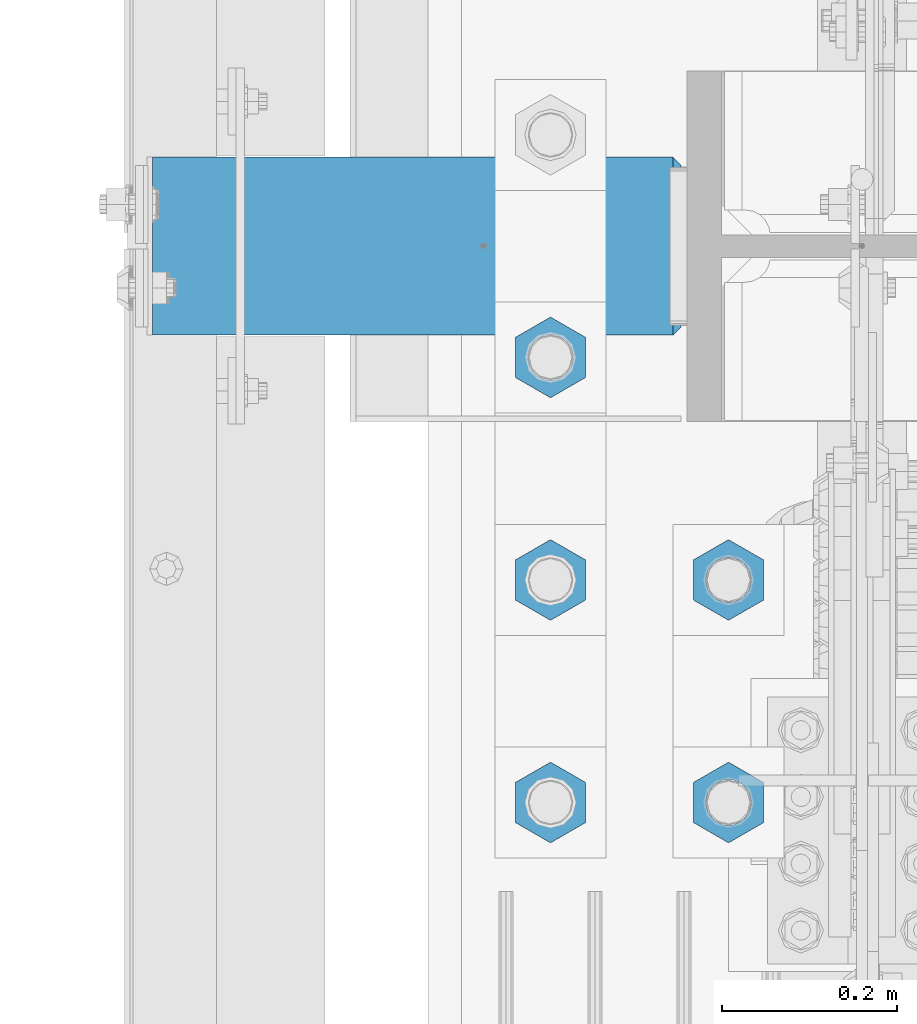
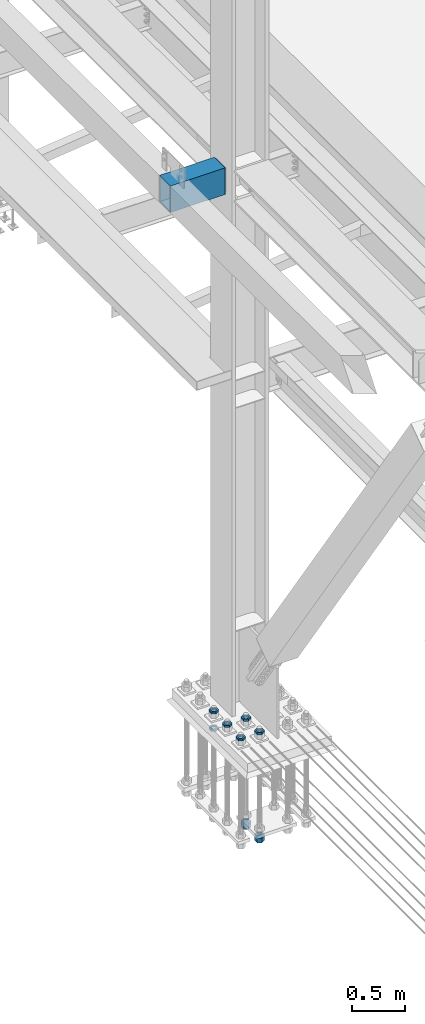
# One storey, part 2382 of 3843: 11 beams, 2 elements without a shape of their own.
"""IFC2X3 building model written with IfcOpenShell, lengths in millimetres."""

from ifc_helpers import new_model, si_unit, frame, origin_with_axes, place, context, subcontext, project, spatial, faceted_brep, material, type_object, element, aggregate, save


model = new_model("IFC2X3")

# Units and contexts
model_context = context("Model", 3, precision=1e-05, world=origin_with_axes())
body_context = subcontext(model_context, "Body", "Model", "MODEL_VIEW")
ifc_project = project(units=[si_unit("LENGTHUNIT", "METRE", prefix="MILLI"), si_unit("AREAUNIT", "SQUARE_METRE"), si_unit("VOLUMEUNIT", "CUBIC_METRE"), si_unit("MASSUNIT", "GRAM", prefix="KILO"), si_unit("TIMEUNIT", "SECOND"), si_unit("PLANEANGLEUNIT", "RADIAN"), si_unit("SOLIDANGLEUNIT", "STERADIAN"), si_unit("THERMODYNAMICTEMPERATUREUNIT", "DEGREE_CELSIUS"), si_unit("LUMINOUSINTENSITYUNIT", "LUMEN")], contexts=[model_context])

# Site, building, storey
site_placement = place(None, origin_with_axes())
site = spatial("IfcSite", under=ifc_project, at=site_placement, CompositionType="ELEMENT")
building_placement = place(site_placement, origin_with_axes())
building = spatial("IfcBuilding", under=site, at=building_placement, Name="Undefined", CompositionType="ELEMENT")
storey_placement = place(building_placement, origin_with_axes())
storey = spatial("IfcBuildingStorey", under=building, at=storey_placement, Name="Undefined", CompositionType="ELEMENT", Elevation=0.0)

# Assembly, beams
assembly_1_placement = place(storey_placement, origin_with_axes())
assembly_1 = element("IfcElementAssembly", 1, at=assembly_1_placement, inside=storey, Name="TEMPLATE", AssemblyPlace="NOTDEFINED", PredefinedType="RIGID_FRAME")
ifc_material_1 = material(Name="STEEL/A572-50")
beam_type_1 = type_object("IfcBeamType", Name="2_HALF_NUT", PredefinedType="NOTDEFINED")
beam_1_placement = place(assembly_1_placement, frame((36220.4, 75501.5, 30060.9), z_axis=(-1.0, 0.0, 0.0), x_axis=(0.0, 0.0, -1.0)))
beam_1 = element("IfcBeam", 2, at=beam_1_placement, type_object=beam_type_1, material=ifc_material_1, Name="NUT", ObjectType="2_HALF_NUT", context=body_context, shape_type="Brep", body=[
    faceted_brep([(0.0, -46.0369987487793, 0.0), (0.0, -23.0184993743896, -39.869213104248), (25.4000000000015, -23.0184993743896, -39.869213104248), (25.4000000000015, -46.0369987487793, 0.0), (0.0, 23.0184993743896, -39.869213104248), (25.4000000000015, 23.0184993743896, -39.869213104248), (0.0, 46.0369987487793, 0.0), (25.4000000000015, 46.0369987487793, 0.0), (0.0, 23.0184993743896, 39.869213104248), (25.4000000000015, 23.0184993743896, 39.869213104248), (0.0, -23.0184993743896, 39.869213104248), (25.4000000000015, -23.0184993743896, 39.869213104248), (0.0, 0.0, 26.1940002441406), (0.0, 11.3650617044477, 23.5999013092805), (25.4000000000015, 11.3650617044477, 23.5999013092805), (25.4000000000015, 0.0, 26.1940002441406), (0.0, 20.4791109456419, 16.3316083006721), (25.4000000000015, 20.4791109456419, 16.3316083006721), (0.0, 25.5370200498292, 5.82867859874386), (25.4000000000015, 25.5370200498292, 5.82867859874386), (0.0, 25.5370200498292, -5.82867859874386), (25.4000000000015, 25.5370200498292, -5.82867859874386), (0.0, 20.4791109456419, -16.3316083006721), (25.4000000000015, 20.4791109456419, -16.3316083006721), (0.0, 11.3650617044477, -23.5999013092805), (25.4000000000015, 11.3650617044477, -23.5999013092805), (0.0, 0.0, -26.1940002441406), (25.4000000000015, 0.0, -26.1940002441406), (0.0, -11.3650617044477, -23.5999013092805), (25.4000000000015, -11.3650617044477, -23.5999013092805), (0.0, -20.4791109456419, -16.3316083006721), (25.4000000000015, -20.4791109456419, -16.3316083006721), (0.0, -25.5370200498292, -5.82867859874386), (25.4000000000015, -25.5370200498292, -5.82867859874386), (0.0, -25.5370200498292, 5.82867859874386), (25.4000000000015, -25.5370200498292, 5.82867859874386), (0.0, -20.4791109456419, 16.3316083006721), (25.4000000000015, -20.4791109456419, 16.3316083006721), (0.0, -11.3650617044477, 23.5999013092805), (25.4000000000015, -11.3650617044477, 23.5999013092805)], [[[0, 1, 2, 3]], [[1, 4, 5, 2]], [[4, 6, 7, 5]], [[6, 8, 9, 7]], [[8, 10, 11, 9]], [[10, 0, 3, 11]], [[12, 13, 14, 15]], [[13, 16, 17, 14]], [[16, 18, 19, 17]], [[18, 20, 21, 19]], [[20, 22, 23, 21]], [[22, 24, 25, 23]], [[24, 26, 27, 25]], [[26, 28, 29, 27]], [[28, 30, 31, 29]], [[30, 32, 33, 31]], [[32, 34, 35, 33]], [[34, 36, 37, 35]], [[36, 38, 39, 37]], [[38, 12, 15, 39]], [[5, 7, 9, 11, 3, 2], [17, 19, 21, 23, 25, 27, 29, 31, 33, 35, 37, 39, 15, 14]], [[10, 8, 6, 4, 1, 0], [38, 36, 34, 32, 30, 28, 26, 24, 22, 20, 18, 16, 13, 12]]]),
])
beam_2_placement = place(assembly_1_placement, frame((36423.6, 74993.5, 30257.75), z_axis=(-1.0, 0.0, 0.0), x_axis=(0.0, 0.0, -1.0)))
beam_2 = element("IfcBeam", 3, at=beam_2_placement, type_object=beam_type_1, material=ifc_material_1, Name="NUT", ObjectType="2_HALF_NUT", context=body_context, shape_type="Brep", body=[
    faceted_brep([(0.0, -46.0369987487793, 0.0), (0.0, -23.0184993743896, -39.869213104248), (25.4000000000015, -23.0184993743896, -39.869213104248), (25.4000000000015, -46.0369987487793, 0.0), (0.0, 23.0184993743896, -39.869213104248), (25.4000000000015, 23.0184993743896, -39.869213104248), (0.0, 46.0369987487793, 0.0), (25.4000000000015, 46.0369987487793, 0.0), (0.0, 23.0184993743896, 39.869213104248), (25.4000000000015, 23.0184993743896, 39.869213104248), (0.0, -23.0184993743896, 39.869213104248), (25.4000000000015, -23.0184993743896, 39.869213104248), (0.0, 0.0, 26.1940002441406), (0.0, 11.3650617044477, 23.5999013092805), (25.4000000000015, 11.3650617044477, 23.5999013092805), (25.4000000000015, 0.0, 26.1940002441406), (0.0, 20.4791109456419, 16.3316083006721), (25.4000000000015, 20.4791109456419, 16.3316083006721), (0.0, 25.5370200498292, 5.82867859874386), (25.4000000000015, 25.5370200498292, 5.82867859874386), (0.0, 25.5370200498292, -5.82867859874386), (25.4000000000015, 25.5370200498292, -5.82867859874386), (0.0, 20.4791109456419, -16.3316083006721), (25.4000000000015, 20.4791109456419, -16.3316083006721), (0.0, 11.3650617044477, -23.5999013092805), (25.4000000000015, 11.3650617044477, -23.5999013092805), (0.0, 0.0, -26.1940002441406), (25.4000000000015, 0.0, -26.1940002441406), (0.0, -11.3650617044477, -23.5999013092805), (25.4000000000015, -11.3650617044477, -23.5999013092805), (0.0, -20.4791109456419, -16.3316083006721), (25.4000000000015, -20.4791109456419, -16.3316083006721), (0.0, -25.5370200498292, -5.82867859874386), (25.4000000000015, -25.5370200498292, -5.82867859874386), (0.0, -25.5370200498292, 5.82867859874386), (25.4000000000015, -25.5370200498292, 5.82867859874386), (0.0, -20.4791109456419, 16.3316083006721), (25.4000000000015, -20.4791109456419, 16.3316083006721), (0.0, -11.3650617044477, 23.5999013092805), (25.4000000000015, -11.3650617044477, 23.5999013092805)], [[[0, 1, 2, 3]], [[1, 4, 5, 2]], [[4, 6, 7, 5]], [[6, 8, 9, 7]], [[8, 10, 11, 9]], [[10, 0, 3, 11]], [[12, 13, 14, 15]], [[13, 16, 17, 14]], [[16, 18, 19, 17]], [[18, 20, 21, 19]], [[20, 22, 23, 21]], [[22, 24, 25, 23]], [[24, 26, 27, 25]], [[26, 28, 29, 27]], [[28, 30, 31, 29]], [[30, 32, 33, 31]], [[32, 34, 35, 33]], [[34, 36, 37, 35]], [[36, 38, 39, 37]], [[38, 12, 15, 39]], [[5, 7, 9, 11, 3, 2], [17, 19, 21, 23, 25, 27, 29, 31, 33, 35, 37, 39, 15, 14]], [[10, 8, 6, 4, 1, 0], [38, 36, 34, 32, 30, 28, 26, 24, 22, 20, 18, 16, 13, 12]]]),
])
beam_3_placement = place(assembly_1_placement, frame((36423.6, 75247.5, 30257.75), z_axis=(-1.0, 0.0, 0.0), x_axis=(0.0, 0.0, -1.0)))
beam_3 = element("IfcBeam", 4, at=beam_3_placement, type_object=beam_type_1, material=ifc_material_1, Name="NUT", ObjectType="2_HALF_NUT", context=body_context, shape_type="Brep", body=[
    faceted_brep([(0.0, -46.0369987487793, 0.0), (0.0, -23.0184993743896, -39.869213104248), (25.4000000000015, -23.0184993743896, -39.869213104248), (25.4000000000015, -46.0369987487793, 0.0), (0.0, 23.0184993743896, -39.869213104248), (25.4000000000015, 23.0184993743896, -39.869213104248), (0.0, 46.0369987487793, 0.0), (25.4000000000015, 46.0369987487793, 0.0), (0.0, 23.0184993743896, 39.869213104248), (25.4000000000015, 23.0184993743896, 39.869213104248), (0.0, -23.0184993743896, 39.869213104248), (25.4000000000015, -23.0184993743896, 39.869213104248), (0.0, 0.0, 26.1940002441406), (0.0, 11.3650617044477, 23.5999013092805), (25.4000000000015, 11.3650617044477, 23.5999013092805), (25.4000000000015, 0.0, 26.1940002441406), (0.0, 20.4791109456419, 16.3316083006721), (25.4000000000015, 20.4791109456419, 16.3316083006721), (0.0, 25.5370200498292, 5.82867859874386), (25.4000000000015, 25.5370200498292, 5.82867859874386), (0.0, 25.5370200498292, -5.82867859874386), (25.4000000000015, 25.5370200498292, -5.82867859874386), (0.0, 20.4791109456419, -16.3316083006721), (25.4000000000015, 20.4791109456419, -16.3316083006721), (0.0, 11.3650617044477, -23.5999013092805), (25.4000000000015, 11.3650617044477, -23.5999013092805), (0.0, 0.0, -26.1940002441406), (25.4000000000015, 0.0, -26.1940002441406), (0.0, -11.3650617044477, -23.5999013092805), (25.4000000000015, -11.3650617044477, -23.5999013092805), (0.0, -20.4791109456419, -16.3316083006721), (25.4000000000015, -20.4791109456419, -16.3316083006721), (0.0, -25.5370200498292, -5.82867859874386), (25.4000000000015, -25.5370200498292, -5.82867859874386), (0.0, -25.5370200498292, 5.82867859874386), (25.4000000000015, -25.5370200498292, 5.82867859874386), (0.0, -20.4791109456419, 16.3316083006721), (25.4000000000015, -20.4791109456419, 16.3316083006721), (0.0, -11.3650617044477, 23.5999013092805), (25.4000000000015, -11.3650617044477, 23.5999013092805)], [[[0, 1, 2, 3]], [[1, 4, 5, 2]], [[4, 6, 7, 5]], [[6, 8, 9, 7]], [[8, 10, 11, 9]], [[10, 0, 3, 11]], [[12, 13, 14, 15]], [[13, 16, 17, 14]], [[16, 18, 19, 17]], [[18, 20, 21, 19]], [[20, 22, 23, 21]], [[22, 24, 25, 23]], [[24, 26, 27, 25]], [[26, 28, 29, 27]], [[28, 30, 31, 29]], [[30, 32, 33, 31]], [[32, 34, 35, 33]], [[34, 36, 37, 35]], [[36, 38, 39, 37]], [[38, 12, 15, 39]], [[5, 7, 9, 11, 3, 2], [17, 19, 21, 23, 25, 27, 29, 31, 33, 35, 37, 39, 15, 14]], [[10, 8, 6, 4, 1, 0], [38, 36, 34, 32, 30, 28, 26, 24, 22, 20, 18, 16, 13, 12]]]),
])
beam_4_placement = place(assembly_1_placement, frame((36220.4, 75501.5, 30257.75), z_axis=(1.0, 0.0, 0.0), x_axis=(0.0, 0.0, -1.0)))
beam_4 = element("IfcBeam", 5, at=beam_4_placement, type_object=beam_type_1, material=ifc_material_1, Name="NUT", ObjectType="2_HALF_NUT", context=body_context, shape_type="Brep", body=[
    faceted_brep([(0.0, -46.0369987487793, 0.0), (0.0, -23.0184993743896, -39.869213104248), (25.4000000000015, -23.0184993743896, -39.869213104248), (25.4000000000015, -46.0369987487793, 0.0), (0.0, 23.0184993743896, -39.869213104248), (25.4000000000015, 23.0184993743896, -39.869213104248), (0.0, 46.0369987487793, 0.0), (25.4000000000015, 46.0369987487793, 0.0), (0.0, 23.0184993743896, 39.869213104248), (25.4000000000015, 23.0184993743896, 39.869213104248), (0.0, -23.0184993743896, 39.869213104248), (25.4000000000015, -23.0184993743896, 39.869213104248), (0.0, 0.0, 26.1940002441406), (0.0, 11.3650617044477, 23.5999013092805), (25.4000000000015, 11.3650617044477, 23.5999013092805), (25.4000000000015, 0.0, 26.1940002441406), (0.0, 20.4791109456419, 16.3316083006721), (25.4000000000015, 20.4791109456419, 16.3316083006721), (0.0, 25.5370200498292, 5.82867859874386), (25.4000000000015, 25.5370200498292, 5.82867859874386), (0.0, 25.5370200498292, -5.82867859874386), (25.4000000000015, 25.5370200498292, -5.82867859874386), (0.0, 20.4791109456419, -16.3316083006721), (25.4000000000015, 20.4791109456419, -16.3316083006721), (0.0, 11.3650617044477, -23.5999013092805), (25.4000000000015, 11.3650617044477, -23.5999013092805), (0.0, 0.0, -26.1940002441406), (25.4000000000015, 0.0, -26.1940002441406), (0.0, -11.3650617044477, -23.5999013092805), (25.4000000000015, -11.3650617044477, -23.5999013092805), (0.0, -20.4791109456419, -16.3316083006721), (25.4000000000015, -20.4791109456419, -16.3316083006721), (0.0, -25.5370200498292, -5.82867859874386), (25.4000000000015, -25.5370200498292, -5.82867859874386), (0.0, -25.5370200498292, 5.82867859874386), (25.4000000000015, -25.5370200498292, 5.82867859874386), (0.0, -20.4791109456419, 16.3316083006721), (25.4000000000015, -20.4791109456419, 16.3316083006721), (0.0, -11.3650617044477, 23.5999013092805), (25.4000000000015, -11.3650617044477, 23.5999013092805)], [[[0, 1, 2, 3]], [[1, 4, 5, 2]], [[4, 6, 7, 5]], [[6, 8, 9, 7]], [[8, 10, 11, 9]], [[10, 0, 3, 11]], [[12, 13, 14, 15]], [[13, 16, 17, 14]], [[16, 18, 19, 17]], [[18, 20, 21, 19]], [[20, 22, 23, 21]], [[22, 24, 25, 23]], [[24, 26, 27, 25]], [[26, 28, 29, 27]], [[28, 30, 31, 29]], [[30, 32, 33, 31]], [[32, 34, 35, 33]], [[34, 36, 37, 35]], [[36, 38, 39, 37]], [[38, 12, 15, 39]], [[5, 7, 9, 11, 3, 2], [17, 19, 21, 23, 25, 27, 29, 31, 33, 35, 37, 39, 15, 14]], [[10, 8, 6, 4, 1, 0], [38, 36, 34, 32, 30, 28, 26, 24, 22, 20, 18, 16, 13, 12]]]),
])
beam_5_placement = place(assembly_1_placement, frame((36220.4, 75247.5, 30257.75), z_axis=(-1.0, 0.0, 0.0), x_axis=(0.0, 0.0, -1.0)))
beam_5 = element("IfcBeam", 6, at=beam_5_placement, type_object=beam_type_1, material=ifc_material_1, Name="NUT", ObjectType="2_HALF_NUT", context=body_context, shape_type="Brep", body=[
    faceted_brep([(0.0, -46.0369987487793, 0.0), (0.0, -23.0184993743896, -39.869213104248), (25.4000000000015, -23.0184993743896, -39.869213104248), (25.4000000000015, -46.0369987487793, 0.0), (0.0, 23.0184993743896, -39.869213104248), (25.4000000000015, 23.0184993743896, -39.869213104248), (0.0, 46.0369987487793, 0.0), (25.4000000000015, 46.0369987487793, 0.0), (0.0, 23.0184993743896, 39.869213104248), (25.4000000000015, 23.0184993743896, 39.869213104248), (0.0, -23.0184993743896, 39.869213104248), (25.4000000000015, -23.0184993743896, 39.869213104248), (0.0, 0.0, 26.1940002441406), (0.0, 11.3650617044477, 23.5999013092805), (25.4000000000015, 11.3650617044477, 23.5999013092805), (25.4000000000015, 0.0, 26.1940002441406), (0.0, 20.4791109456419, 16.3316083006721), (25.4000000000015, 20.4791109456419, 16.3316083006721), (0.0, 25.5370200498292, 5.82867859874386), (25.4000000000015, 25.5370200498292, 5.82867859874386), (0.0, 25.5370200498292, -5.82867859874386), (25.4000000000015, 25.5370200498292, -5.82867859874386), (0.0, 20.4791109456419, -16.3316083006721), (25.4000000000015, 20.4791109456419, -16.3316083006721), (0.0, 11.3650617044477, -23.5999013092805), (25.4000000000015, 11.3650617044477, -23.5999013092805), (0.0, 0.0, -26.1940002441406), (25.4000000000015, 0.0, -26.1940002441406), (0.0, -11.3650617044477, -23.5999013092805), (25.4000000000015, -11.3650617044477, -23.5999013092805), (0.0, -20.4791109456419, -16.3316083006721), (25.4000000000015, -20.4791109456419, -16.3316083006721), (0.0, -25.5370200498292, -5.82867859874386), (25.4000000000015, -25.5370200498292, -5.82867859874386), (0.0, -25.5370200498292, 5.82867859874386), (25.4000000000015, -25.5370200498292, 5.82867859874386), (0.0, -20.4791109456419, 16.3316083006721), (25.4000000000015, -20.4791109456419, 16.3316083006721), (0.0, -11.3650617044477, 23.5999013092805), (25.4000000000015, -11.3650617044477, 23.5999013092805)], [[[0, 1, 2, 3]], [[1, 4, 5, 2]], [[4, 6, 7, 5]], [[6, 8, 9, 7]], [[8, 10, 11, 9]], [[10, 0, 3, 11]], [[12, 13, 14, 15]], [[13, 16, 17, 14]], [[16, 18, 19, 17]], [[18, 20, 21, 19]], [[20, 22, 23, 21]], [[22, 24, 25, 23]], [[24, 26, 27, 25]], [[26, 28, 29, 27]], [[28, 30, 31, 29]], [[30, 32, 33, 31]], [[32, 34, 35, 33]], [[34, 36, 37, 35]], [[36, 38, 39, 37]], [[38, 12, 15, 39]], [[5, 7, 9, 11, 3, 2], [17, 19, 21, 23, 25, 27, 29, 31, 33, 35, 37, 39, 15, 14]], [[10, 8, 6, 4, 1, 0], [38, 36, 34, 32, 30, 28, 26, 24, 22, 20, 18, 16, 13, 12]]]),
])
beam_6_placement = place(assembly_1_placement, frame((36220.4, 74993.5, 30257.75), z_axis=(-1.0, 0.0, 0.0), x_axis=(0.0, 0.0, -1.0)))
beam_6 = element("IfcBeam", 7, at=beam_6_placement, type_object=beam_type_1, material=ifc_material_1, Name="NUT", ObjectType="2_HALF_NUT", context=body_context, shape_type="Brep", body=[
    faceted_brep([(0.0, -46.0369987487793, 0.0), (0.0, -23.0184993743896, -39.869213104248), (25.4000000000015, -23.0184993743896, -39.869213104248), (25.4000000000015, -46.0369987487793, 0.0), (0.0, 23.0184993743896, -39.869213104248), (25.4000000000015, 23.0184993743896, -39.869213104248), (0.0, 46.0369987487793, 0.0), (25.4000000000015, 46.0369987487793, 0.0), (0.0, 23.0184993743896, 39.869213104248), (25.4000000000015, 23.0184993743896, 39.869213104248), (0.0, -23.0184993743896, 39.869213104248), (25.4000000000015, -23.0184993743896, 39.869213104248), (0.0, 0.0, 26.1940002441406), (0.0, 11.3650617044477, 23.5999013092805), (25.4000000000015, 11.3650617044477, 23.5999013092805), (25.4000000000015, 0.0, 26.1940002441406), (0.0, 20.4791109456419, 16.3316083006721), (25.4000000000015, 20.4791109456419, 16.3316083006721), (0.0, 25.5370200498292, 5.82867859874386), (25.4000000000015, 25.5370200498292, 5.82867859874386), (0.0, 25.5370200498292, -5.82867859874386), (25.4000000000015, 25.5370200498292, -5.82867859874386), (0.0, 20.4791109456419, -16.3316083006721), (25.4000000000015, 20.4791109456419, -16.3316083006721), (0.0, 11.3650617044477, -23.5999013092805), (25.4000000000015, 11.3650617044477, -23.5999013092805), (0.0, 0.0, -26.1940002441406), (25.4000000000015, 0.0, -26.1940002441406), (0.0, -11.3650617044477, -23.5999013092805), (25.4000000000015, -11.3650617044477, -23.5999013092805), (0.0, -20.4791109456419, -16.3316083006721), (25.4000000000015, -20.4791109456419, -16.3316083006721), (0.0, -25.5370200498292, -5.82867859874386), (25.4000000000015, -25.5370200498292, -5.82867859874386), (0.0, -25.5370200498292, 5.82867859874386), (25.4000000000015, -25.5370200498292, 5.82867859874386), (0.0, -20.4791109456419, 16.3316083006721), (25.4000000000015, -20.4791109456419, 16.3316083006721), (0.0, -11.3650617044477, 23.5999013092805), (25.4000000000015, -11.3650617044477, 23.5999013092805)], [[[0, 1, 2, 3]], [[1, 4, 5, 2]], [[4, 6, 7, 5]], [[6, 8, 9, 7]], [[8, 10, 11, 9]], [[10, 0, 3, 11]], [[12, 13, 14, 15]], [[13, 16, 17, 14]], [[16, 18, 19, 17]], [[18, 20, 21, 19]], [[20, 22, 23, 21]], [[22, 24, 25, 23]], [[24, 26, 27, 25]], [[26, 28, 29, 27]], [[28, 30, 31, 29]], [[30, 32, 33, 31]], [[32, 34, 35, 33]], [[34, 36, 37, 35]], [[36, 38, 39, 37]], [[38, 12, 15, 39]], [[5, 7, 9, 11, 3, 2], [17, 19, 21, 23, 25, 27, 29, 31, 33, 35, 37, 39, 15, 14]], [[10, 8, 6, 4, 1, 0], [38, 36, 34, 32, 30, 28, 26, 24, 22, 20, 18, 16, 13, 12]]]),
])
beam_7_placement = place(assembly_1_placement, frame((36423.6, 74993.5, 29070.3), z_axis=(-1.0, 0.0, 0.0), x_axis=(0.0, 0.0, -1.0)))
beam_7 = element("IfcBeam", 8, at=beam_7_placement, type_object=beam_type_1, material=ifc_material_1, Name="NUT", ObjectType="2_HALF_NUT", context=body_context, shape_type="Brep", body=[
    faceted_brep([(0.0, -46.0369987487793, 0.0), (0.0, -23.0184993743896, -39.869213104248), (25.4000000000015, -23.0184993743896, -39.869213104248), (25.4000000000015, -46.0369987487793, 0.0), (0.0, 23.0184993743896, -39.869213104248), (25.4000000000015, 23.0184993743896, -39.869213104248), (0.0, 46.0369987487793, 0.0), (25.4000000000015, 46.0369987487793, 0.0), (0.0, 23.0184993743896, 39.869213104248), (25.4000000000015, 23.0184993743896, 39.869213104248), (0.0, -23.0184993743896, 39.869213104248), (25.4000000000015, -23.0184993743896, 39.869213104248), (0.0, 0.0, 26.1940002441406), (0.0, 11.3650617044477, 23.5999013092805), (25.4000000000015, 11.3650617044477, 23.5999013092805), (25.4000000000015, 0.0, 26.1940002441406), (0.0, 20.4791109456419, 16.3316083006721), (25.4000000000015, 20.4791109456419, 16.3316083006721), (0.0, 25.5370200498292, 5.82867859874386), (25.4000000000015, 25.5370200498292, 5.82867859874386), (0.0, 25.5370200498292, -5.82867859874386), (25.4000000000015, 25.5370200498292, -5.82867859874386), (0.0, 20.4791109456419, -16.3316083006721), (25.4000000000015, 20.4791109456419, -16.3316083006721), (0.0, 11.3650617044477, -23.5999013092805), (25.4000000000015, 11.3650617044477, -23.5999013092805), (0.0, 0.0, -26.1940002441406), (25.4000000000015, 0.0, -26.1940002441406), (0.0, -11.3650617044477, -23.5999013092805), (25.4000000000015, -11.3650617044477, -23.5999013092805), (0.0, -20.4791109456419, -16.3316083006721), (25.4000000000015, -20.4791109456419, -16.3316083006721), (0.0, -25.5370200498292, -5.82867859874386), (25.4000000000015, -25.5370200498292, -5.82867859874386), (0.0, -25.5370200498292, 5.82867859874386), (25.4000000000015, -25.5370200498292, 5.82867859874386), (0.0, -20.4791109456419, 16.3316083006721), (25.4000000000015, -20.4791109456419, 16.3316083006721), (0.0, -11.3650617044477, 23.5999013092805), (25.4000000000015, -11.3650617044477, 23.5999013092805)], [[[0, 1, 2, 3]], [[1, 4, 5, 2]], [[4, 6, 7, 5]], [[6, 8, 9, 7]], [[8, 10, 11, 9]], [[10, 0, 3, 11]], [[12, 13, 14, 15]], [[13, 16, 17, 14]], [[16, 18, 19, 17]], [[18, 20, 21, 19]], [[20, 22, 23, 21]], [[22, 24, 25, 23]], [[24, 26, 27, 25]], [[26, 28, 29, 27]], [[28, 30, 31, 29]], [[30, 32, 33, 31]], [[32, 34, 35, 33]], [[34, 36, 37, 35]], [[36, 38, 39, 37]], [[38, 12, 15, 39]], [[5, 7, 9, 11, 3, 2], [17, 19, 21, 23, 25, 27, 29, 31, 33, 35, 37, 39, 15, 14]], [[10, 8, 6, 4, 1, 0], [38, 36, 34, 32, 30, 28, 26, 24, 22, 20, 18, 16, 13, 12]]]),
])
beam_8_placement = place(assembly_1_placement, frame((36423.6, 75247.5, 29070.3), z_axis=(-1.0, 0.0, 0.0), x_axis=(0.0, 0.0, -1.0)))
beam_8 = element("IfcBeam", 9, at=beam_8_placement, type_object=beam_type_1, material=ifc_material_1, Name="NUT", ObjectType="2_HALF_NUT", context=body_context, shape_type="Brep", body=[
    faceted_brep([(0.0, -46.0369987487793, 0.0), (0.0, -23.0184993743896, -39.869213104248), (25.4000000000015, -23.0184993743896, -39.869213104248), (25.4000000000015, -46.0369987487793, 0.0), (0.0, 23.0184993743896, -39.869213104248), (25.4000000000015, 23.0184993743896, -39.869213104248), (0.0, 46.0369987487793, 0.0), (25.4000000000015, 46.0369987487793, 0.0), (0.0, 23.0184993743896, 39.869213104248), (25.4000000000015, 23.0184993743896, 39.869213104248), (0.0, -23.0184993743896, 39.869213104248), (25.4000000000015, -23.0184993743896, 39.869213104248), (0.0, 0.0, 26.1940002441406), (0.0, 11.3650617044477, 23.5999013092805), (25.4000000000015, 11.3650617044477, 23.5999013092805), (25.4000000000015, 0.0, 26.1940002441406), (0.0, 20.4791109456419, 16.3316083006721), (25.4000000000015, 20.4791109456419, 16.3316083006721), (0.0, 25.5370200498292, 5.82867859874386), (25.4000000000015, 25.5370200498292, 5.82867859874386), (0.0, 25.5370200498292, -5.82867859874386), (25.4000000000015, 25.5370200498292, -5.82867859874386), (0.0, 20.4791109456419, -16.3316083006721), (25.4000000000015, 20.4791109456419, -16.3316083006721), (0.0, 11.3650617044477, -23.5999013092805), (25.4000000000015, 11.3650617044477, -23.5999013092805), (0.0, 0.0, -26.1940002441406), (25.4000000000015, 0.0, -26.1940002441406), (0.0, -11.3650617044477, -23.5999013092805), (25.4000000000015, -11.3650617044477, -23.5999013092805), (0.0, -20.4791109456419, -16.3316083006721), (25.4000000000015, -20.4791109456419, -16.3316083006721), (0.0, -25.5370200498292, -5.82867859874386), (25.4000000000015, -25.5370200498292, -5.82867859874386), (0.0, -25.5370200498292, 5.82867859874386), (25.4000000000015, -25.5370200498292, 5.82867859874386), (0.0, -20.4791109456419, 16.3316083006721), (25.4000000000015, -20.4791109456419, 16.3316083006721), (0.0, -11.3650617044477, 23.5999013092805), (25.4000000000015, -11.3650617044477, 23.5999013092805)], [[[0, 1, 2, 3]], [[1, 4, 5, 2]], [[4, 6, 7, 5]], [[6, 8, 9, 7]], [[8, 10, 11, 9]], [[10, 0, 3, 11]], [[12, 13, 14, 15]], [[13, 16, 17, 14]], [[16, 18, 19, 17]], [[18, 20, 21, 19]], [[20, 22, 23, 21]], [[22, 24, 25, 23]], [[24, 26, 27, 25]], [[26, 28, 29, 27]], [[28, 30, 31, 29]], [[30, 32, 33, 31]], [[32, 34, 35, 33]], [[34, 36, 37, 35]], [[36, 38, 39, 37]], [[38, 12, 15, 39]], [[5, 7, 9, 11, 3, 2], [17, 19, 21, 23, 25, 27, 29, 31, 33, 35, 37, 39, 15, 14]], [[10, 8, 6, 4, 1, 0], [38, 36, 34, 32, 30, 28, 26, 24, 22, 20, 18, 16, 13, 12]]]),
])
beam_type_2 = type_object("IfcBeamType", Name="2_HEAVY_HEX_NUT", PredefinedType="NOTDEFINED")
beam_9_placement = place(assembly_1_placement, frame((36423.6, 74993.5, 29044.9), z_axis=(-1.0, 0.0, 0.0), x_axis=(0.0, 0.0, -1.0)))
beam_9 = element("IfcBeam", 10, at=beam_9_placement, type_object=beam_type_2, material=ifc_material_1, Name="NUT", ObjectType="2_HEAVY_HEX_NUT", context=body_context, shape_type="Brep", body=[
    faceted_brep([(0.0, -46.0369987487793, 0.0), (0.0, -23.0184993743896, -39.869213104248), (50.7999999999993, -23.0184993743896, -39.869213104248), (50.7999999999993, -46.0369987487793, 0.0), (0.0, 23.0184993743896, -39.869213104248), (50.7999999999993, 23.0184993743896, -39.869213104248), (0.0, 46.0369987487793, 0.0), (50.7999999999993, 46.0369987487793, 0.0), (0.0, 23.0184993743896, 39.869213104248), (50.7999999999993, 23.0184993743896, 39.869213104248), (0.0, -23.0184993743896, 39.869213104248), (50.7999999999993, -23.0184993743896, 39.869213104248), (0.0, 0.0, 26.1940002441406), (0.0, 11.3650617044477, 23.5999013092805), (50.7999999999993, 11.3650617044477, 23.5999013092805), (50.7999999999993, 0.0, 26.1940002441406), (0.0, 20.4791109456419, 16.3316083006721), (50.7999999999993, 20.4791109456419, 16.3316083006721), (0.0, 25.5370200498292, 5.82867859874386), (50.7999999999993, 25.5370200498292, 5.82867859874386), (0.0, 25.5370200498292, -5.82867859874386), (50.7999999999993, 25.5370200498292, -5.82867859874386), (0.0, 20.4791109456419, -16.3316083006721), (50.7999999999993, 20.4791109456419, -16.3316083006721), (0.0, 11.3650617044477, -23.5999013092805), (50.7999999999993, 11.3650617044477, -23.5999013092805), (0.0, 0.0, -26.1940002441406), (50.7999999999993, 0.0, -26.1940002441406), (0.0, -11.3650617044477, -23.5999013092805), (50.7999999999993, -11.3650617044477, -23.5999013092805), (0.0, -20.4791109456419, -16.3316083006721), (50.7999999999993, -20.4791109456419, -16.3316083006721), (0.0, -25.5370200498292, -5.82867859874386), (50.7999999999993, -25.5370200498292, -5.82867859874386), (0.0, -25.5370200498292, 5.82867859874386), (50.7999999999993, -25.5370200498292, 5.82867859874386), (0.0, -20.4791109456419, 16.3316083006721), (50.7999999999993, -20.4791109456419, 16.3316083006721), (0.0, -11.3650617044477, 23.5999013092805), (50.7999999999993, -11.3650617044477, 23.5999013092805)], [[[0, 1, 2, 3]], [[1, 4, 5, 2]], [[4, 6, 7, 5]], [[6, 8, 9, 7]], [[8, 10, 11, 9]], [[10, 0, 3, 11]], [[12, 13, 14, 15]], [[13, 16, 17, 14]], [[16, 18, 19, 17]], [[18, 20, 21, 19]], [[20, 22, 23, 21]], [[22, 24, 25, 23]], [[24, 26, 27, 25]], [[26, 28, 29, 27]], [[28, 30, 31, 29]], [[30, 32, 33, 31]], [[32, 34, 35, 33]], [[34, 36, 37, 35]], [[36, 38, 39, 37]], [[38, 12, 15, 39]], [[5, 7, 9, 11, 3, 2], [17, 19, 21, 23, 25, 27, 29, 31, 33, 35, 37, 39, 15, 14]], [[10, 8, 6, 4, 1, 0], [38, 36, 34, 32, 30, 28, 26, 24, 22, 20, 18, 16, 13, 12]]]),
])
beam_10_placement = place(assembly_1_placement, frame((36423.6, 75247.5, 29044.9), z_axis=(-1.0, 0.0, 0.0), x_axis=(0.0, 0.0, -1.0)))
beam_10 = element("IfcBeam", 11, at=beam_10_placement, type_object=beam_type_2, material=ifc_material_1, Name="NUT", ObjectType="2_HEAVY_HEX_NUT", context=body_context, shape_type="Brep", body=[
    faceted_brep([(0.0, -46.0369987487793, 0.0), (0.0, -23.0184993743896, -39.869213104248), (50.7999999999993, -23.0184993743896, -39.869213104248), (50.7999999999993, -46.0369987487793, 0.0), (0.0, 23.0184993743896, -39.869213104248), (50.7999999999993, 23.0184993743896, -39.869213104248), (0.0, 46.0369987487793, 0.0), (50.7999999999993, 46.0369987487793, 0.0), (0.0, 23.0184993743896, 39.869213104248), (50.7999999999993, 23.0184993743896, 39.869213104248), (0.0, -23.0184993743896, 39.869213104248), (50.7999999999993, -23.0184993743896, 39.869213104248), (0.0, 0.0, 26.1940002441406), (0.0, 11.3650617044477, 23.5999013092805), (50.7999999999993, 11.3650617044477, 23.5999013092805), (50.7999999999993, 0.0, 26.1940002441406), (0.0, 20.4791109456419, 16.3316083006721), (50.7999999999993, 20.4791109456419, 16.3316083006721), (0.0, 25.5370200498292, 5.82867859874386), (50.7999999999993, 25.5370200498292, 5.82867859874386), (0.0, 25.5370200498292, -5.82867859874386), (50.7999999999993, 25.5370200498292, -5.82867859874386), (0.0, 20.4791109456419, -16.3316083006721), (50.7999999999993, 20.4791109456419, -16.3316083006721), (0.0, 11.3650617044477, -23.5999013092805), (50.7999999999993, 11.3650617044477, -23.5999013092805), (0.0, 0.0, -26.1940002441406), (50.7999999999993, 0.0, -26.1940002441406), (0.0, -11.3650617044477, -23.5999013092805), (50.7999999999993, -11.3650617044477, -23.5999013092805), (0.0, -20.4791109456419, -16.3316083006721), (50.7999999999993, -20.4791109456419, -16.3316083006721), (0.0, -25.5370200498292, -5.82867859874386), (50.7999999999993, -25.5370200498292, -5.82867859874386), (0.0, -25.5370200498292, 5.82867859874386), (50.7999999999993, -25.5370200498292, 5.82867859874386), (0.0, -20.4791109456419, 16.3316083006721), (50.7999999999993, -20.4791109456419, 16.3316083006721), (0.0, -11.3650617044477, 23.5999013092805), (50.7999999999993, -11.3650617044477, 23.5999013092805)], [[[0, 1, 2, 3]], [[1, 4, 5, 2]], [[4, 6, 7, 5]], [[6, 8, 9, 7]], [[8, 10, 11, 9]], [[10, 0, 3, 11]], [[12, 13, 14, 15]], [[13, 16, 17, 14]], [[16, 18, 19, 17]], [[18, 20, 21, 19]], [[20, 22, 23, 21]], [[22, 24, 25, 23]], [[24, 26, 27, 25]], [[26, 28, 29, 27]], [[28, 30, 31, 29]], [[30, 32, 33, 31]], [[32, 34, 35, 33]], [[34, 36, 37, 35]], [[36, 38, 39, 37]], [[38, 12, 15, 39]], [[5, 7, 9, 11, 3, 2], [17, 19, 21, 23, 25, 27, 29, 31, 33, 35, 37, 39, 15, 14]], [[10, 8, 6, 4, 1, 0], [38, 36, 34, 32, 30, 28, 26, 24, 22, 20, 18, 16, 13, 12]]]),
])
aggregate(assembly_1, [beam_1, beam_2, beam_3, beam_4, beam_5, beam_6, beam_9, beam_7, beam_10, beam_8])

# Assembly, beam
assembly_2_placement = place(storey_placement, origin_with_axes())
assembly_2 = element("IfcElementAssembly", 12, at=assembly_2_placement, inside=storey, Name="COLUMN", AssemblyPlace="NOTDEFINED", PredefinedType="RIGID_FRAME")
ifc_material_2 = material()
beam_type_3 = type_object("IfcBeamType", Name="HSS12X8X3/8", PredefinedType="NOTDEFINED")
beam_11_placement = place(assembly_2_placement, frame((35760.025, 75628.5, 36252.15), z_axis=(0.0, 0.0, 1.0), x_axis=(1.0, 0.0, 0.0)))
beam_11 = element("IfcBeam", 13, at=beam_11_placement, type_object=beam_type_3, material=ifc_material_2, Name="BEAM", ObjectType="HSS12X8X3/8", context=body_context, shape_type="Brep", body=[
    faceted_brep([(609.600000000006, 92.0749999999971, 142.875), (609.600000000006, 92.0749999999971, -142.875), (600.075000000004, 101.600000000006, -152.400000000001), (600.075000000004, 101.600000000006, 152.400000000001), (609.600000000006, -92.0749999999971, -142.875), (600.075000000004, -101.600000000006, -152.400000000001), (609.600000000006, -92.0749999999971, 142.875), (600.075000000004, -101.600000000006, 152.400000000001), (6.35000000002037, 92.0749999999971, 142.875), (6.35000000002037, 92.0749999999971, -142.875), (6.35000000002037, -92.0749999999971, 142.875), (6.35000000002037, -92.0749999999971, -142.875), (6.35000000002037, -101.600000000006, -152.400000000001), (6.35000000002037, -101.600000000006, 152.400000000001), (6.35000000002037, 101.600000000006, 152.400000000001), (6.35000000002037, 101.600000000006, -152.400000000001)], [[[0, 1, 2, 3]], [[4, 5, 2, 1]], [[6, 7, 5, 4]], [[8, 9, 1, 0]], [[10, 8, 0, 6]], [[11, 10, 6, 4]], [[9, 11, 4, 1]], [[12, 13, 14, 15], [8, 10, 11, 9]], [[15, 14, 3, 2]], [[12, 15, 2, 5]], [[13, 12, 5, 7]], [[14, 13, 7, 3]], [[0, 3, 7, 6]]]),
])
aggregate(assembly_2, [beam_11])

save(model, "model.ifc")
